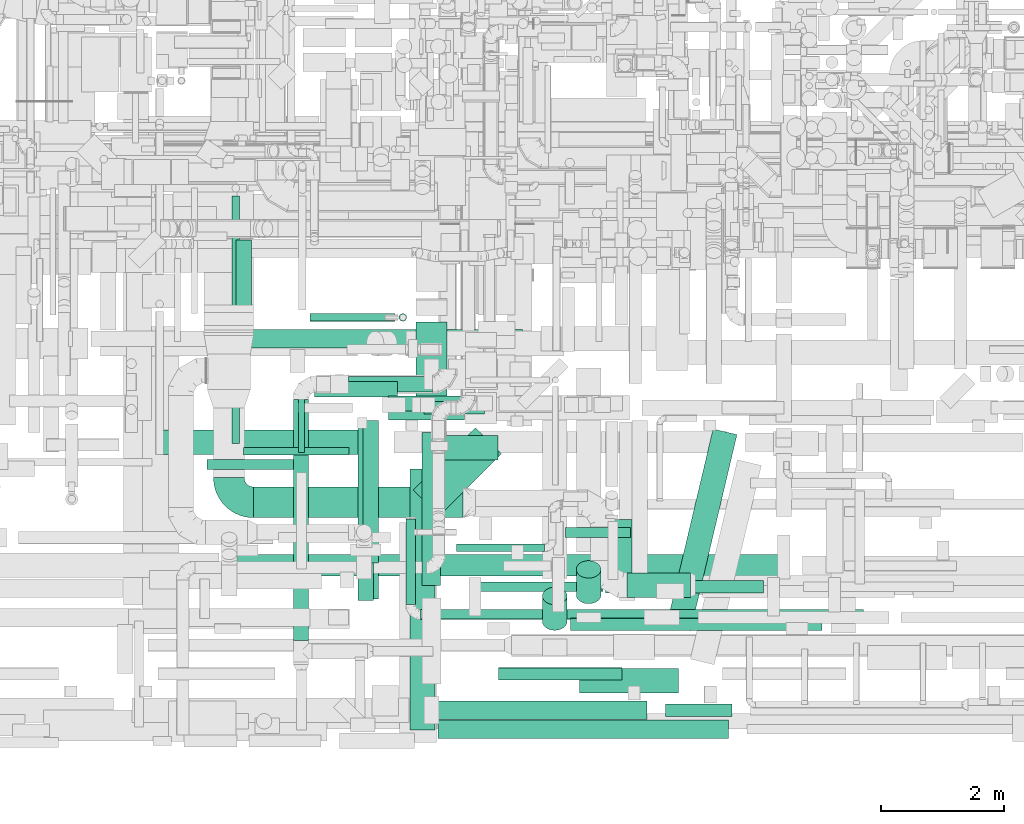
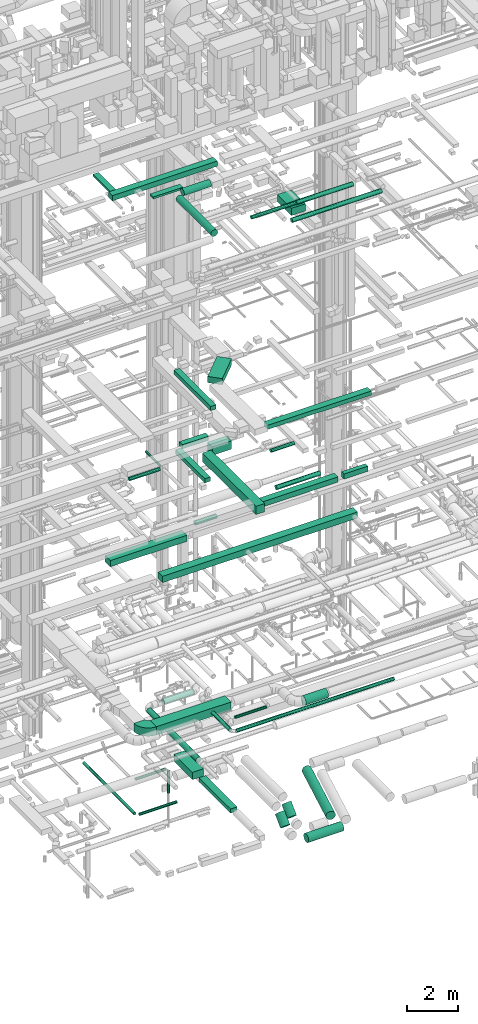
# One storey, part 38 of 337: 42 flow segments, 1 flow fitting.
"""IFC2X3 building model written with IfcOpenShell, lengths in millimetres."""

from ifc_helpers import new_model, entity, si_unit, converted_unit, derived_unit, direction, frame, frame_2d, origin, origin_2d_with_axis, place, context, subcontext, project, spatial, polyline, circle_curve, parameter, trimmed, segment, composite_curve, rectangle, circle, outline, extrude, source, transform, mapped, material, type_object, type_shapes, element, save


model = new_model("IFC2X3")

# Units and contexts
model_context = context("Model", 3, precision=0.01, world=origin(), true_north=direction((6.12303176911189e-17, 1.0)))
body_context = subcontext(model_context, "Body", "Model", "MODEL_VIEW")
ifc_project = project(units=[si_unit("LENGTHUNIT", "METRE", prefix="MILLI"), si_unit("AREAUNIT", "SQUARE_METRE"), si_unit("VOLUMEUNIT", "CUBIC_METRE"), converted_unit("PLANEANGLEUNIT", "DEGREE", entity("IfcRatioMeasure", 0.0174532925199433), si_unit("PLANEANGLEUNIT", "RADIAN"), dimensions=[0, 0, 0, 0, 0, 0, 0]), si_unit("MASSUNIT", "GRAM", prefix="KILO"), derived_unit("MASSDENSITYUNIT", [(si_unit("MASSUNIT", "GRAM", prefix="KILO"), 1), (si_unit("LENGTHUNIT", "METRE"), -3)]), derived_unit("MOMENTOFINERTIAUNIT", [(si_unit("LENGTHUNIT", "METRE"), 4)]), si_unit("TIMEUNIT", "SECOND"), si_unit("FREQUENCYUNIT", "HERTZ"), si_unit("THERMODYNAMICTEMPERATUREUNIT", "DEGREE_CELSIUS"), derived_unit("THERMALTRANSMITTANCEUNIT", [(si_unit("MASSUNIT", "GRAM", prefix="KILO"), 1), (si_unit("THERMODYNAMICTEMPERATUREUNIT", "KELVIN"), -1), (si_unit("TIMEUNIT", "SECOND"), -3)]), derived_unit("VOLUMETRICFLOWRATEUNIT", [(si_unit("LENGTHUNIT", "METRE"), 3), (si_unit("TIMEUNIT", "SECOND"), -1)]), derived_unit("MASSFLOWRATEUNIT", [(si_unit("MASSUNIT", "GRAM", prefix="KILO"), 1), (si_unit("TIMEUNIT", "SECOND"), -1)]), derived_unit("ROTATIONALFREQUENCYUNIT", [(si_unit("TIMEUNIT", "SECOND"), -1)]), si_unit("ELECTRICCURRENTUNIT", "AMPERE"), si_unit("ELECTRICVOLTAGEUNIT", "VOLT"), si_unit("POWERUNIT", "WATT"), si_unit("FORCEUNIT", "NEWTON", prefix="KILO"), si_unit("ILLUMINANCEUNIT", "LUX"), si_unit("LUMINOUSFLUXUNIT", "LUMEN"), si_unit("LUMINOUSINTENSITYUNIT", "CANDELA"), derived_unit("USERDEFINED", [(si_unit("MASSUNIT", "GRAM", prefix="KILO"), -1), (si_unit("LENGTHUNIT", "METRE"), -2), (si_unit("TIMEUNIT", "SECOND"), 3), (si_unit("LUMINOUSFLUXUNIT", "LUMEN"), 1)]), derived_unit("LINEARVELOCITYUNIT", [(si_unit("LENGTHUNIT", "METRE"), 1), (si_unit("TIMEUNIT", "SECOND"), -1)]), si_unit("PRESSUREUNIT", "PASCAL"), derived_unit("USERDEFINED", [(si_unit("LENGTHUNIT", "METRE"), -2), (si_unit("MASSUNIT", "GRAM", prefix="KILO"), 1), (si_unit("TIMEUNIT", "SECOND"), -2)]), derived_unit("LINEARFORCEUNIT", [(si_unit("MASSUNIT", "GRAM", prefix="KILO"), 1), (si_unit("LENGTHUNIT", "METRE"), 1), (si_unit("TIMEUNIT", "SECOND"), -2), (si_unit("LENGTHUNIT", "METRE"), -1)]), derived_unit("PLANARFORCEUNIT", [(si_unit("MASSUNIT", "GRAM", prefix="KILO"), 1), (si_unit("LENGTHUNIT", "METRE"), 1), (si_unit("TIMEUNIT", "SECOND"), -2), (si_unit("LENGTHUNIT", "METRE"), -2)])], contexts=[model_context])

# Site, building, storey
site_placement = place(None, origin())
site = spatial("IfcSite", under=ifc_project, at=site_placement, CompositionType="ELEMENT")
building_placement = place(site_placement, origin())
building = spatial("IfcBuilding", under=site, at=building_placement, CompositionType="ELEMENT")
storey_placement = place(building_placement, origin())
storey = spatial("IfcBuildingStorey", under=building, at=storey_placement, CompositionType="ELEMENT", Elevation=0.0)

# Flow segments
duct_segment_type_1 = type_object("IfcDuctSegmentType", PredefinedType="NOTDEFINED")
flow_segment_1_placement = place(storey_placement, frame((49213.6, 5628.36, -875.0)))
element("IfcFlowSegment", 1, at=flow_segment_1_placement, inside=storey, type_object=duct_segment_type_1, context=body_context, shape_type="SweptSolid", body=[
    extrude(rectangle(XDim=1446.47429187333, YDim=499.999999999999, at=origin_2d_with_axis()), frame((250.0, 723.24, 0.0), z_axis=(0.0, 0.0, 1.0), x_axis=(0.0, -1.0, 0.0)), (0.0, 0.0, 1.0), 350.0),
])
flow_segment_2_placement = place(storey_placement, frame((49313.6, 2795.77, -800.0)))
element("IfcFlowSegment", 2, at=flow_segment_2_placement, inside=storey, type_object=duct_segment_type_1, context=body_context, shape_type="SweptSolid", body=[
    extrude(rectangle(XDim=2482.5949383323, YDim=300.000000000001, at=origin_2d_with_axis()), frame((150.0, 1241.3, 0.0), z_axis=(0.0, 0.0, 1.0), x_axis=(0.0, -1.0, 0.0)), (0.0, 0.0, 1.0), 200.0),
])
flow_segment_3_placement = place(storey_placement, frame((45067.3, 4920.54, 11250.0)))
element("IfcFlowSegment", 3, at=flow_segment_3_placement, inside=storey, type_object=duct_segment_type_1, context=body_context, shape_type="SweptSolid", body=[
    extrude(rectangle(XDim=3490.0, YDim=400.0, at=origin_2d_with_axis()), frame((1745.0, 200.0, 0.0)), (0.0, 0.0, 1.0), 300.000000000001),
])
flow_segment_4_placement = place(storey_placement, frame((46311.81, 2947.88, 11250.0)))
element("IfcFlowSegment", 4, at=flow_segment_4_placement, inside=storey, type_object=duct_segment_type_1, context=body_context, shape_type="SweptSolid", body=[
    extrude(rectangle(XDim=8870.11051182412, YDim=350.0, at=origin_2d_with_axis()), frame((4435.06, 175.0, 0.0)), (0.0, 0.0, 1.0), 300.000000000001),
])
flow_segment_5_placement = place(storey_placement, frame((46575.84, 3896.24, 3250.0)))
element("IfcFlowSegment", 5, at=flow_segment_5_placement, inside=storey, type_object=duct_segment_type_1, context=body_context, shape_type="SweptSolid", body=[
    extrude(rectangle(XDim=3400.00000000001, YDim=500.0, at=origin_2d_with_axis()), frame((1700.0, 250.0, 0.0)), (0.0, 0.0, 1.0), 400.0),
])
flow_segment_6_placement = place(storey_placement, frame((48270.22, 2552.06, 19075.0)))
element("IfcFlowSegment", 6, at=flow_segment_6_placement, inside=storey, type_object=duct_segment_type_1, context=body_context, shape_type="SweptSolid", body=[
    extrude(rectangle(XDim=2898.75000000008, YDim=250.000000000004, at=origin_2d_with_axis()), frame((125.0, 1449.38, 0.0), z_axis=(0.0, 0.0, 1.0), x_axis=(0.0, 1.0, 0.0)), (0.0, 0.0, 1.0), 200.000000000002),
])
flow_segment_7_placement = place(storey_placement, frame((49166.9, 3924.08, 19025.0)))
element("IfcFlowSegment", 7, at=flow_segment_7_placement, inside=storey, type_object=duct_segment_type_1, context=body_context, shape_type="SweptSolid", body=[
    extrude(rectangle(XDim=1427.20779386422, YDim=599.999999999998, at=origin_2d_with_axis()), frame((716.73, 716.73, 0.0), z_axis=(0.0, 0.0, 1.0), x_axis=(-0.707106781186553, -0.707106781186542, 0.0)), (0.0, 0.0, 1.0), 300.000000000001),
])
flow_segment_8_placement = place(storey_placement, frame((49567.23, 313.31, 19075.0)))
element("IfcFlowSegment", 8, at=flow_segment_8_placement, inside=storey, type_object=duct_segment_type_1, context=body_context, shape_type="SweptSolid", body=[
    extrude(rectangle(XDim=4720.00000000005, YDim=300.0, at=origin_2d_with_axis()), frame((2360.0, 150.0, 0.0)), (0.0, 0.0, 1.0), 200.000000000002),
])
flow_segment_9_placement = place(storey_placement, frame((49539.29, 620.66, 15175.0)))
element("IfcFlowSegment", 9, at=flow_segment_9_placement, inside=storey, type_object=duct_segment_type_1, context=body_context, shape_type="SweptSolid", body=[
    extrude(rectangle(XDim=3420.00000000005, YDim=300.0, at=origin_2d_with_axis()), frame((1710.0, 150.0, 0.0)), (0.0, 0.0, 1.0), 249.999999999999),
])
flow_segment_10_placement = place(storey_placement, frame((48356.01, 3165.44, 15200.0)))
element("IfcFlowSegment", 10, at=flow_segment_10_placement, inside=storey, type_object=duct_segment_type_1, context=body_context, shape_type="SweptSolid", body=[
    extrude(rectangle(XDim=2310.0, YDim=250.000000000004, at=origin_2d_with_axis()), frame((125.0, 1155.0, 0.0), z_axis=(0.0, 0.0, 1.0), x_axis=(0.0, 1.0, 0.0)), (0.0, 0.0, 1.0), 199.999999999998),
])
flow_segment_11_placement = place(storey_placement, frame((48756.01, 5625.44, 15200.0)))
element("IfcFlowSegment", 11, at=flow_segment_11_placement, inside=storey, type_object=duct_segment_type_1, context=body_context, shape_type="SweptSolid", body=[
    extrude(rectangle(XDim=1199.16660940672, YDim=249.999999999999, at=origin_2d_with_axis()), frame((599.58, 125.0, 0.0)), (0.0, 0.0, 1.0), 199.999999999998),
])
flow_segment_12_placement = place(storey_placement, frame((49119.29, 454.02, 15050.0)))
element("IfcFlowSegment", 12, at=flow_segment_12_placement, inside=storey, type_object=duct_segment_type_1, context=body_context, shape_type="SweptSolid", body=[
    extrude(rectangle(XDim=4230.00000000001, YDim=400.000000000004, at=origin_2d_with_axis()), frame((200.0, 2115.0, 0.0), z_axis=(0.0, 0.0, 1.0), x_axis=(0.0, -1.0, 0.0)), (0.0, 0.0, 1.0), 400.0),
])
flow_segment_13_placement = place(storey_placement, frame((49669.29, 4834.02, 15050.0)))
element("IfcFlowSegment", 13, at=flow_segment_13_placement, inside=storey, type_object=duct_segment_type_1, context=body_context, shape_type="SweptSolid", body=[
    extrude(rectangle(XDim=876.021507213497, YDim=400.0, at=origin_2d_with_axis()), frame((438.01, 200.0, 0.0), z_axis=(0.0, 0.0, 1.0), x_axis=(-1.0, 0.0, 0.0)), (0.0, 0.0, 1.0), 400.0),
])
flow_segment_14_placement = place(storey_placement, frame((53259.29, 670.66, 15175.0)))
element("IfcFlowSegment", 14, at=flow_segment_14_placement, inside=storey, type_object=duct_segment_type_1, context=body_context, shape_type="SweptSolid", body=[
    extrude(rectangle(XDim=1080.00000000001, YDim=200.0, at=origin_2d_with_axis()), frame((540.0, 100.0, 0.0)), (0.0, 0.0, 1.0), 249.999999999999),
])
flow_segment_15_placement = place(storey_placement, frame((46160.82, 6649.99, 27425.0)))
element("IfcFlowSegment", 15, at=flow_segment_15_placement, inside=storey, type_object=duct_segment_type_1, context=body_context, shape_type="SweptSolid", body=[
    extrude(rectangle(XDim=4780.00000000009, YDim=300.0, at=origin_2d_with_axis()), frame((2390.0, 150.0, 0.0), z_axis=(0.0, 0.0, 1.0), x_axis=(-1.0, 0.0, 0.0)), (0.0, 0.0, 1.0), 250.000000000004),
])
flow_segment_16_placement = place(storey_placement, frame((46289.52, 6969.99, 27500.0)))
element("IfcFlowSegment", 16, at=flow_segment_16_placement, inside=storey, type_object=duct_segment_type_1, context=body_context, shape_type="SweptSolid", body=[
    extrude(rectangle(XDim=1435.79999999624, YDim=250.000000000004, at=origin_2d_with_axis()), frame((125.0, 717.9, 0.0), z_axis=(0.0, 0.0, 1.0), x_axis=(0.0, 1.0, 0.0)), (0.0, 0.0, 1.0), 100.000000000003),
])
flow_segment_17_placement = place(storey_placement, frame((47564.17, 5855.79, 27500.0)))
element("IfcFlowSegment", 17, at=flow_segment_17_placement, inside=storey, type_object=duct_segment_type_1, context=body_context, shape_type="SweptSolid", body=[
    extrude(rectangle(XDim=1345.00000000001, YDim=250.000000000001, at=origin_2d_with_axis()), frame((672.5, 125.0, 0.0)), (0.0, 0.0, 1.0), 100.000000000003),
])
flow_segment_18_placement = place(storey_placement, frame((52066.36, 2770.67, 27000.0)))
element("IfcFlowSegment", 18, at=flow_segment_18_placement, inside=storey, type_object=duct_segment_type_1, context=body_context, shape_type="SweptSolid", body=[
    extrude(rectangle(XDim=1099.99999999998, YDim=650.0, at=origin_2d_with_axis()), frame((325.0, 550.0, 0.0), z_axis=(0.0, 0.0, 1.0), x_axis=(0.0, 1.0, 0.0)), (0.0, 0.0, 1.0), 349.999999999998),
])
duct_segment_type_2 = type_object("IfcDuctSegmentType", PredefinedType="NOTDEFINED")
flow_segment_19_placement = place(storey_placement, frame((51812.5, 2499.27, -1975.86)))
element("IfcFlowSegment", 19, at=flow_segment_19_placement, inside=storey, type_object=duct_segment_type_2, context=body_context, shape_type="SweptSolid", body=[
    extrude(circle(Radius=200.0, at=origin_2d_with_axis()), frame((201.6, 143.02, 143.02), z_axis=(0.0, 0.707106781186522, 0.707106781186573), x_axis=(-1.0, 0.0, 0.0)), (0.0, 0.0, 1.0), 587.867965644059),
])
flow_segment_20_placement = place(storey_placement, frame((53277.16, 2058.35, -2151.6)))
element("IfcFlowSegment", 20, at=flow_segment_20_placement, inside=storey, type_object=duct_segment_type_2, context=body_context, shape_type="SweptSolid", body=[
    extrude(circle(Radius=200.0, at=origin_2d_with_axis()), frame((196.21, 47.69, 201.6), z_axis=(0.230466234443146, 0.97308032288275, 0.0), x_axis=(0.97308032288275, -0.230466234443146, 0.0)), (0.0, 0.0, 1.0), 3272.98056764663),
])
flow_segment_21_placement = place(storey_placement, frame((51262.56, 2067.69, -1975.86)))
element("IfcFlowSegment", 21, at=flow_segment_21_placement, inside=storey, type_object=duct_segment_type_2, context=body_context, shape_type="SweptSolid", body=[
    extrude(circle(Radius=200.0, at=origin_2d_with_axis()), frame((201.6, 143.02, 143.02), z_axis=(0.0, 0.707106781186546, 0.707106781186549), x_axis=(-1.0, 0.0, 0.0)), (0.0, 0.0, 1.0), 587.867967804478),
])
flow_segment_22_placement = place(storey_placement, frame((51864.16, 1047.13, -2151.6)))
element("IfcFlowSegment", 22, at=flow_segment_22_placement, inside=storey, type_object=duct_segment_type_2, context=body_context, shape_type="SweptSolid", body=[
    extrude(circle(Radius=200.0, at=origin_2d_with_axis()), frame((0.0, 201.6, 201.6), z_axis=(1.0, 0.0, 0.0), x_axis=(0.0, -1.0, 0.0)), (0.0, 0.0, 1.0), 1604.59195470507),
])
flow_segment_23_placement = place(storey_placement, frame((47493.94, 7082.14, -1224.1)))
element("IfcFlowSegment", 23, at=flow_segment_23_placement, inside=storey, type_object=duct_segment_type_2, context=body_context, shape_type="SweptSolid", body=[
    extrude(circle(Radius=62.5, at=origin_2d_with_axis()), frame((0.0, 64.1, 64.1), z_axis=(1.0, 0.0, 0.0), x_axis=(0.0, -1.0, 0.0)), (0.0, 0.0, 1.0), 1380.43421999998),
])
flow_segment_24_placement = place(storey_placement, frame((48935.28, 7082.14, -2335.0)))
element("IfcFlowSegment", 24, at=flow_segment_24_placement, inside=storey, type_object=duct_segment_type_2, context=body_context, shape_type="SweptSolid", body=[
    extrude(circle(Radius=62.5, at=origin_2d_with_axis()), frame((64.1, 64.1, 0.0), z_axis=(0.0, 0.0, 1.0), x_axis=(0.0, -1.0, 0.0)), (0.0, 0.0, 1.0), 1050.0),
])
flow_segment_25_placement = place(storey_placement, frame((46225.29, 5098.33, -1224.1)))
element("IfcFlowSegment", 25, at=flow_segment_25_placement, inside=storey, type_object=duct_segment_type_2, context=body_context, shape_type="SweptSolid", body=[
    extrude(circle(Radius=62.5, at=origin_2d_with_axis()), frame((64.1, 0.0, 64.1), z_axis=(0.0, 1.0, 0.0), x_axis=(-1.0, 0.0, 0.0)), (0.0, 0.0, 1.0), 4021.67244635073),
])
flow_segment_26_placement = place(storey_placement, frame((46414.39, 4909.24, -1224.1)))
element("IfcFlowSegment", 26, at=flow_segment_26_placement, inside=storey, type_object=duct_segment_type_2, context=body_context, shape_type="SweptSolid", body=[
    extrude(circle(Radius=62.5, at=origin_2d_with_axis()), frame((0.0, 64.1, 64.1), z_axis=(1.0, 0.0, 0.0), x_axis=(0.0, -1.0, 0.0)), (0.0, 0.0, 1.0), 1709.99999999984),
])
flow_segment_27_placement = place(storey_placement, frame((49345.82, 5578.95, 11298.4)))
element("IfcFlowSegment", 27, at=flow_segment_27_placement, inside=storey, type_object=duct_segment_type_2, context=body_context, shape_type="SweptSolid", body=[
    extrude(circle(Radius=100.0, at=origin_2d_with_axis()), frame((0.0, 101.6, 101.6), z_axis=(1.0, 0.0, 0.0), x_axis=(0.0, -1.0, 0.0)), (0.0, 0.0, 1.0), 979.999999999916),
])
flow_segment_28_placement = place(storey_placement, frame((52640.84, 2602.15, 3248.4)))
element("IfcFlowSegment", 28, at=flow_segment_28_placement, inside=storey, type_object=duct_segment_type_2, context=body_context, shape_type="SweptSolid", body=[
    extrude(circle(Radius=200.0, at=origin_2d_with_axis()), frame((0.0, 201.6, 201.6), z_axis=(1.0, 0.0, 0.0), x_axis=(0.0, -1.0, 0.0)), (0.0, 0.0, 1.0), 1025.00000000003),
])
flow_segment_29_placement = place(storey_placement, frame((49045.01, 2488.65, 3368.4)))
element("IfcFlowSegment", 29, at=flow_segment_29_placement, inside=storey, type_object=duct_segment_type_2, context=body_context, shape_type="SweptSolid", body=[
    extrude(circle(Radius=80.0, at=origin_2d_with_axis()), frame((81.6, 0.0, 81.6), z_axis=(0.0, 1.0, 0.0), x_axis=(1.0, 0.0, 0.0)), (0.0, 0.0, 1.0), 1387.59280380318),
])
flow_segment_30_placement = place(storey_placement, frame((49286.6, 2247.05, 3368.4)))
element("IfcFlowSegment", 30, at=flow_segment_30_placement, inside=storey, type_object=duct_segment_type_2, context=body_context, shape_type="SweptSolid", body=[
    extrude(circle(Radius=80.0, at=origin_2d_with_axis()), frame((0.0, 81.6, 81.6), z_axis=(1.0, 0.0, 0.0), x_axis=(0.0, -1.0, 0.0)), (0.0, 0.0, 1.0), 7187.25094619677),
])
flow_segment_31_placement = place(storey_placement, frame((47219.8, 1902.79, 2873.4)))
element("IfcFlowSegment", 31, at=flow_segment_31_placement, inside=storey, type_object=duct_segment_type_2, context=body_context, shape_type="SweptSolid", body=[
    extrude(circle(Radius=125.0, at=origin_2d_with_axis()), frame((126.6, 0.0, 126.6), z_axis=(0.0, 1.0, 0.0), x_axis=(-1.0, 0.0, 0.0)), (0.0, 0.0, 1.0), 3910.36716839662),
])
flow_segment_32_placement = place(storey_placement, frame((47301.0, 4952.09, 15248.4)))
element("IfcFlowSegment", 32, at=flow_segment_32_placement, inside=storey, type_object=duct_segment_type_2, context=body_context, shape_type="SweptSolid", body=[
    extrude(circle(Radius=50.0, at=origin_2d_with_axis()), frame((51.6, 0.0, 51.6), z_axis=(0.0, 1.0, 0.0), x_axis=(1.0, 0.0, 0.0)), (0.0, 0.0, 1.0), 1120.0),
])
flow_segment_33_placement = place(storey_placement, frame((45822.59, 4680.5, 15218.4)))
element("IfcFlowSegment", 33, at=flow_segment_33_placement, inside=storey, type_object=duct_segment_type_2, context=body_context, shape_type="SweptSolid", body=[
    extrude(circle(Radius=80.0, at=origin_2d_with_axis()), frame((0.0, 81.6, 81.6), z_axis=(1.0, 0.0, 0.0), x_axis=(0.0, 1.0, 0.0)), (0.0, 0.0, 1.0), 1400.0),
])
flow_segment_34_placement = place(storey_placement, frame((51636.01, 3576.55, 15218.4)))
element("IfcFlowSegment", 34, at=flow_segment_34_placement, inside=storey, type_object=duct_segment_type_2, context=body_context, shape_type="SweptSolid", body=[
    extrude(circle(Radius=80.0, at=origin_2d_with_axis()), frame((0.0, 81.6, 81.6), z_axis=(1.0, 0.0, 0.0), x_axis=(0.0, 1.0, 0.0)), (0.0, 0.0, 1.0), 1059.99999614166),
])
flow_segment_35_placement = place(storey_placement, frame((50552.2, 1260.8, 15198.4)))
element("IfcFlowSegment", 35, at=flow_segment_35_placement, inside=storey, type_object=duct_segment_type_2, context=body_context, shape_type="SweptSolid", body=[
    extrude(circle(Radius=100.0, at=origin_2d_with_axis()), frame((0.0, 101.6, 101.6), z_axis=(1.0, 0.0, 0.0), x_axis=(0.0, 1.0, 0.0)), (0.0, 0.0, 1.0), 2000.00000000001),
])
flow_segment_36_placement = place(storey_placement, frame((52284.64, 2674.37, 27448.4)))
element("IfcFlowSegment", 36, at=flow_segment_36_placement, inside=storey, type_object=duct_segment_type_2, context=body_context, shape_type="SweptSolid", body=[
    extrude(circle(Radius=100.0, at=origin_2d_with_axis()), frame((0.0, 101.6, 101.6), z_axis=(1.0, 0.0, 0.0), x_axis=(0.0, 1.0, 0.0)), (0.0, 0.0, 1.0), 2569.94435033076),
])
flow_segment_37_placement = place(storey_placement, frame((50238.85, 2694.37, 27468.4)))
element("IfcFlowSegment", 37, at=flow_segment_37_placement, inside=storey, type_object=duct_segment_type_2, context=body_context, shape_type="SweptSolid", body=[
    extrude(circle(Radius=80.0, at=origin_2d_with_axis()), frame((0.0, 81.6, 81.6), z_axis=(1.0, 0.0, 0.0), x_axis=(0.0, 1.0, 0.0)), (0.0, 0.0, 1.0), 2005.79291070888),
])
flow_segment_38_placement = place(storey_placement, frame((48764.15, 5479.7, 27390.9)))
element("IfcFlowSegment", 38, at=flow_segment_38_placement, inside=storey, type_object=duct_segment_type_2, context=body_context, shape_type="SweptSolid", body=[
    extrude(circle(Radius=157.5, at=origin_2d_with_axis()), frame((0.0, 159.1, 159.1), z_axis=(1.0, 0.0, 0.0), x_axis=(0.0, -1.0, 0.0)), (0.0, 0.0, 1.0), 1232.29195016151),
])
flow_segment_39_placement = place(storey_placement, frame((48290.06, 2575.04, 27390.9)))
element("IfcFlowSegment", 39, at=flow_segment_39_placement, inside=storey, type_object=duct_segment_type_2, context=body_context, shape_type="SweptSolid", body=[
    extrude(circle(Radius=157.5, at=origin_2d_with_axis()), frame((159.1, 0.0, 159.1), z_axis=(0.0, 1.0, 0.0), x_axis=(-1.0, 0.0, 0.0)), (0.0, 0.0, 1.0), 2748.75000000005),
])
flow_segment_40_placement = place(storey_placement, frame((51723.69, 2064.01, 27158.4)))
element("IfcFlowSegment", 40, at=flow_segment_40_placement, inside=storey, type_object=duct_segment_type_2, context=body_context, shape_type="SweptSolid", body=[
    extrude(circle(Radius=100.0, at=origin_2d_with_axis()), frame((0.0, 101.6, 101.6), z_axis=(1.0, 0.0, 0.0), x_axis=(0.0, 1.0, 0.0)), (0.0, 0.0, 1.0), 4081.25000000003),
])
flow_segment_41_placement = place(storey_placement, frame((48115.0, 5936.56, 2873.4)))
element("IfcFlowSegment", 41, at=flow_segment_41_placement, inside=storey, type_object=duct_segment_type_2, context=body_context, shape_type="SweptSolid", body=[
    extrude(circle(Radius=125.0, at=origin_2d_with_axis()), frame((0.0, 126.6, 126.6), z_axis=(1.0, 0.0, 0.0), x_axis=(0.0, 1.0, 0.0)), (0.0, 0.0, 1.0), 1362.54081057491),
])
flow_segment_42_placement = place(storey_placement, frame((49866.6, 3346.19, 3185.9)))
element("IfcFlowSegment", 42, at=flow_segment_42_placement, inside=storey, type_object=duct_segment_type_2, context=body_context, shape_type="SweptSolid", body=[
    extrude(circle(Radius=62.5, at=origin_2d_with_axis()), frame((0.0, 64.1, 64.1), z_axis=(1.0, 0.0, 0.0), x_axis=(0.0, 1.0, 0.0)), (0.0, 0.0, 1.0), 1433.39638157523),
])

# Flow fitting
ifc_material = material()
duct_fitting_type = type_object("IfcDuctFittingType", PredefinedType="NOTDEFINED", material=ifc_material)
shared_shape = source(origin(), body_context, "Body", "SweptSolid", [
    extrude(outline(composite_curve([segment(polyline([(-450.0, -200.0), (50.0, -200.0)]), True, "CONTINUOUS"), segment(trimmed(circle_curve(frame_2d((200.0, -200.0), x_axis=(0.0, 1.0)), 150.0), [parameter(0.0)], [parameter(90.0000000000001)], True, "PARAMETER"), False, "CONTINUOUS"), segment(polyline([(200.0, -50.0), (200.0, 450.0)]), True, "CONTINUOUS"), segment(trimmed(circle_curve(frame_2d((200.0, -200.0), x_axis=(0.0, 1.0)), 650.0), [parameter(0.0)], [parameter(90.0000000000001)], True, "PARAMETER"), True, "CONTINUOUS")], self_intersect=False)), frame((-200.0, 200.0, -200.0), z_axis=(0.0, 0.0, 1.0), x_axis=(-1.0, 0.0, 0.0)), (0.0, 0.0, 1.0), 400.0),
])
type_shapes(duct_fitting_type, [shared_shape])
flow_fitting_placement = place(storey_placement, frame((46175.84, 4146.24, 3450.0), z_axis=(0.0, 0.0, 1.0), x_axis=(0.0, -1.0, 0.0)))
element("IfcFlowFitting", 43, at=flow_fitting_placement, inside=storey, type_object=duct_fitting_type, material=ifc_material, context=body_context, shape_type="MappedRepresentation", body=[
    mapped(shared_shape, transform((0.0, 0.0, 0.0), scale=1.0)),
])

save(model, "model.ifc")
